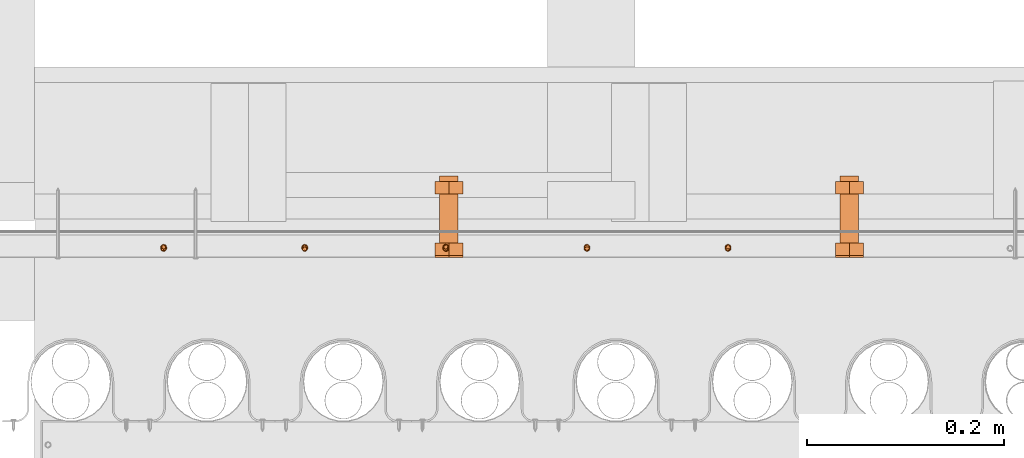
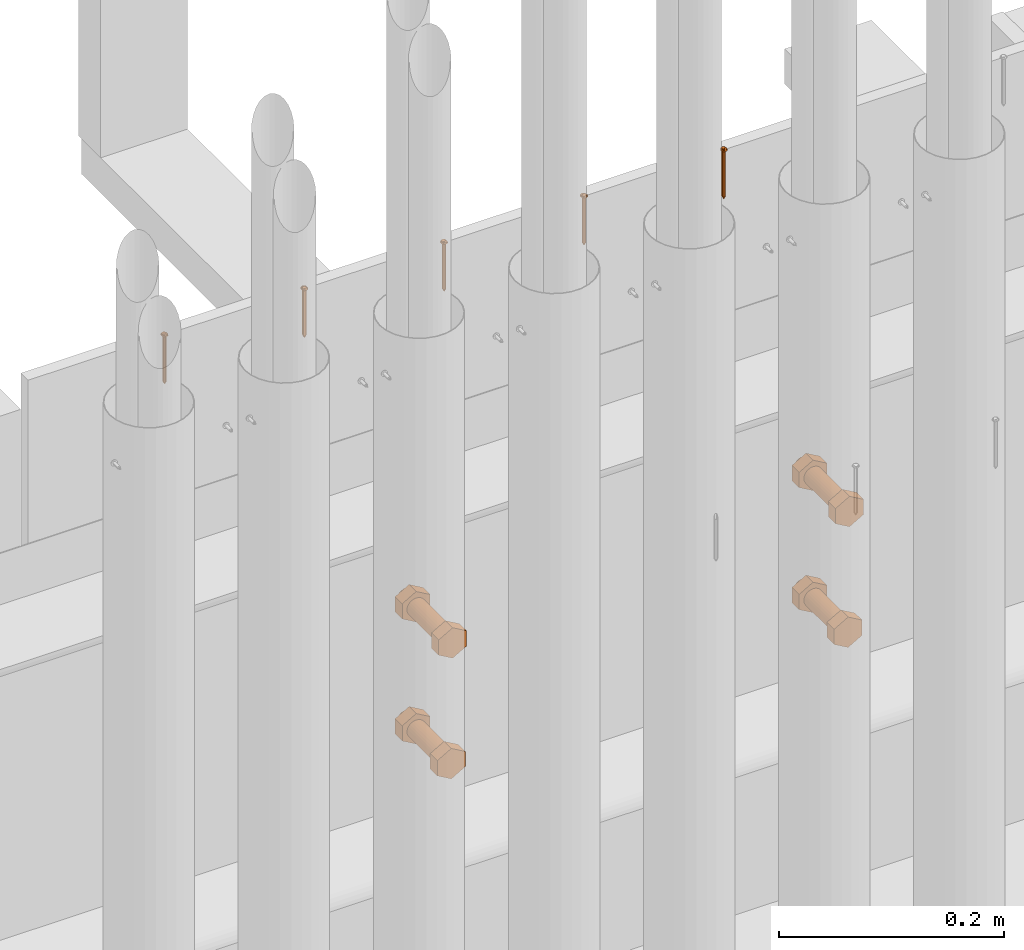
# One storey, part 30 of 44: 14 proxies.
"""IFC4 building model written with IfcOpenShell, lengths in feet."""

from ifc_helpers import new_model, entity, si_unit, converted_unit, derived_unit, direction, frame, frame_2d, origin, place, context, subcontext, project, spatial, polyline, circle, outline, extrude, source, transform, mapped, material, type_object, type_shapes, element, save


model = new_model("IFC4")

# Units and contexts
model_context = context("Model", 3, precision=0.0001, world=origin(), true_north=direction((6.12303176911189e-17, 1.0)))
body_context = subcontext(model_context, "Body", "Model", "MODEL_VIEW")
ifc_project = project(units=[converted_unit("LENGTHUNIT", "FOOT", entity("IfcRatioMeasure", 0.3048), si_unit("LENGTHUNIT", "METRE"), dimensions=[1, 0, 0, 0, 0, 0, 0]), converted_unit("AREAUNIT", "SQUARE FOOT", entity("IfcRatioMeasure", 0.09290304), si_unit("AREAUNIT", "SQUARE_METRE"), dimensions=[2, 0, 0, 0, 0, 0, 0]), converted_unit("VOLUMEUNIT", "CUBIC FOOT", entity("IfcRatioMeasure", 0.028316846592), si_unit("VOLUMEUNIT", "CUBIC_METRE"), dimensions=[3, 0, 0, 0, 0, 0, 0]), converted_unit("PLANEANGLEUNIT", "DEGREE", entity("IfcRatioMeasure", 0.0174532925199433), si_unit("PLANEANGLEUNIT", "RADIAN"), dimensions=[0, 0, 0, 0, 0, 0, 0]), si_unit("MASSUNIT", "GRAM", prefix="KILO"), derived_unit("MASSDENSITYUNIT", [(si_unit("MASSUNIT", "GRAM", prefix="KILO"), 1), (si_unit("LENGTHUNIT", "METRE"), -3)]), derived_unit("MOMENTOFINERTIAUNIT", [(si_unit("LENGTHUNIT", "METRE"), 4)]), si_unit("TIMEUNIT", "SECOND"), si_unit("FREQUENCYUNIT", "HERTZ"), si_unit("THERMODYNAMICTEMPERATUREUNIT", "DEGREE_CELSIUS"), derived_unit("THERMALTRANSMITTANCEUNIT", [(si_unit("MASSUNIT", "GRAM", prefix="KILO"), 1), (si_unit("THERMODYNAMICTEMPERATUREUNIT", "KELVIN"), -1), (si_unit("TIMEUNIT", "SECOND"), -3)]), derived_unit("VOLUMETRICFLOWRATEUNIT", [(si_unit("LENGTHUNIT", "METRE"), 3), (si_unit("TIMEUNIT", "SECOND"), -1)]), si_unit("ELECTRICCURRENTUNIT", "AMPERE"), si_unit("ELECTRICVOLTAGEUNIT", "VOLT"), si_unit("POWERUNIT", "WATT"), si_unit("FORCEUNIT", "NEWTON"), si_unit("ILLUMINANCEUNIT", "LUX"), si_unit("LUMINOUSFLUXUNIT", "LUMEN"), si_unit("LUMINOUSINTENSITYUNIT", "CANDELA"), derived_unit("USERDEFINED", [(si_unit("MASSUNIT", "GRAM", prefix="KILO"), -1), (si_unit("LENGTHUNIT", "METRE"), -2), (si_unit("TIMEUNIT", "SECOND"), 3), (si_unit("LUMINOUSFLUXUNIT", "LUMEN"), 1)]), derived_unit("LINEARVELOCITYUNIT", [(si_unit("LENGTHUNIT", "METRE"), 1), (si_unit("TIMEUNIT", "SECOND"), -1)]), si_unit("PRESSUREUNIT", "PASCAL"), derived_unit("USERDEFINED", [(si_unit("LENGTHUNIT", "METRE"), -2), (si_unit("MASSUNIT", "GRAM", prefix="KILO"), 1), (si_unit("TIMEUNIT", "SECOND"), -2)]), derived_unit("LINEARFORCEUNIT", [(si_unit("MASSUNIT", "GRAM", prefix="KILO"), 1), (si_unit("LENGTHUNIT", "METRE"), 1), (si_unit("TIMEUNIT", "SECOND"), -2), (si_unit("LENGTHUNIT", "METRE"), -1)]), derived_unit("PLANARFORCEUNIT", [(si_unit("MASSUNIT", "GRAM", prefix="KILO"), 1), (si_unit("LENGTHUNIT", "METRE"), 1), (si_unit("TIMEUNIT", "SECOND"), -2), (si_unit("LENGTHUNIT", "METRE"), -2)])], contexts=[model_context])

# Site, building, storey
site_placement = place(None, origin())
site = spatial("IfcSite", under=ifc_project, at=site_placement, CompositionType="ELEMENT")
building_placement = place(site_placement, origin())
building = spatial("IfcBuilding", under=site, at=building_placement, CompositionType="ELEMENT")
storey_placement = place(building_placement, origin())
storey = spatial("IfcBuildingStorey", under=building, at=storey_placement, CompositionType="ELEMENT", Elevation=0.0)

# Proxies
ifc_material_1 = material(Category="Materials")
building_element_proxy_type_1 = type_object("IfcBuildingElementProxyType", PredefinedType="NOTDEFINED", material=ifc_material_1)
cartesian_point_1 = entity("IfcCartesianPoint", [0.0, -0.00520833333344464, -0.164340723974429])
vertex_point_1 = entity("IfcVertexPoint", cartesian_point_1)
cartesian_point_2 = entity("IfcCartesianPoint", [0.0, 0.00520833333334609, -0.164340723974429])
vertex_point_2 = entity("IfcVertexPoint", cartesian_point_2)
cartesian_point_3 = entity("IfcCartesianPoint", [0.0, 0.0, -0.164340723974429])
ifc_direction_1 = entity("IfcDirection", [0.0, 0.0, 1.0])
ifc_direction_2 = entity("IfcDirection", [0.0, 1.0, 0.0])
edge_curve_1 = entity("IfcEdgeCurve", vertex_point_1, vertex_point_2, entity("IfcTrimmedCurve", entity("IfcCircle", entity("IfcAxis2Placement3D", cartesian_point_3, ifc_direction_1, ifc_direction_2), 0.00520833333339537), [cartesian_point_1], [cartesian_point_2], True, "CARTESIAN"), True)
vertex_point_3 = entity("IfcVertexPoint", cartesian_point_3)
ifc_direction_3 = entity("IfcDirection", [0.0, -1.0, 0.0])
edge_curve_2 = entity("IfcEdgeCurve", vertex_point_2, vertex_point_3, entity("IfcTrimmedCurve", entity("IfcLine", cartesian_point_2, entity("IfcVector", ifc_direction_3, 1.0)), [cartesian_point_2], [cartesian_point_3], True, "CARTESIAN"), True)
edge_curve_3 = entity("IfcEdgeCurve", vertex_point_3, vertex_point_1, entity("IfcTrimmedCurve", entity("IfcLine", cartesian_point_3, entity("IfcVector", ifc_direction_3, 1.0)), [cartesian_point_3], [cartesian_point_1], True, "CARTESIAN"), True)
edge_curve_4 = entity("IfcEdgeCurve", vertex_point_2, vertex_point_1, entity("IfcTrimmedCurve", entity("IfcCircle", entity("IfcAxis2Placement3D", cartesian_point_3, ifc_direction_1, ifc_direction_2), 0.00520833333339537), [cartesian_point_2], [cartesian_point_1], True, "CARTESIAN"), True)
cartesian_point_4 = entity("IfcCartesianPoint", [0.0, 0.0, -0.174757390640864])
vertex_point_4 = entity("IfcVertexPoint", cartesian_point_4)
edge_curve_5 = entity("IfcEdgeCurve", vertex_point_4, vertex_point_2, entity("IfcTrimmedCurve", entity("IfcLine", cartesian_point_4, entity("IfcVector", entity("IfcDirection", [0.0, 0.447213595512766, 0.894427190993512]), 1.0)), [cartesian_point_4], [cartesian_point_2], True, "CARTESIAN"), True)
edge_curve_6 = entity("IfcEdgeCurve", vertex_point_1, vertex_point_4, entity("IfcTrimmedCurve", entity("IfcLine", cartesian_point_1, entity("IfcVector", entity("IfcDirection", [0.0, 0.447213595512751, -0.894427190993519]), 1.0)), [cartesian_point_1], [cartesian_point_4], True, "CARTESIAN"), True)
cartesian_point_5 = entity("IfcCartesianPoint", [-0.0052083333333639, 0.0, -0.164340723974429])
cartesian_point_6 = entity("IfcCartesianPoint", [0.0, 0.0, -0.169209575232054])
ifc_direction_4 = entity("IfcDirection", [0.0, 0.0, -1.0])
cartesian_point_7 = entity("IfcCartesianPoint", [0.0, 0.0104166666665518, 0.0])
vertex_point_5 = entity("IfcVertexPoint", cartesian_point_7)
cartesian_point_8 = entity("IfcCartesianPoint", [0.0, -0.0104166666669052, 0.0])
vertex_point_6 = entity("IfcVertexPoint", cartesian_point_8)
cartesian_point_9 = entity("IfcCartesianPoint", [0.0, 0.0, 0.0])
ifc_direction_5 = entity("IfcDirection", [0.0, 0.0, -1.0])
ifc_direction_6 = entity("IfcDirection", [0.0, -1.0, 0.0])
edge_curve_7 = entity("IfcEdgeCurve", vertex_point_5, vertex_point_6, entity("IfcTrimmedCurve", entity("IfcCircle", entity("IfcAxis2Placement3D", cartesian_point_9, ifc_direction_5, ifc_direction_6), 0.0104166666667285), [cartesian_point_7], [cartesian_point_8], True, "CARTESIAN"), True)
vertex_point_7 = entity("IfcVertexPoint", cartesian_point_9)
ifc_direction_7 = entity("IfcDirection", [0.0, 1.0, 0.0])
edge_curve_8 = entity("IfcEdgeCurve", vertex_point_6, vertex_point_7, entity("IfcTrimmedCurve", entity("IfcLine", cartesian_point_8, entity("IfcVector", ifc_direction_7, 1.0)), [cartesian_point_8], [cartesian_point_9], True, "CARTESIAN"), True)
edge_curve_9 = entity("IfcEdgeCurve", vertex_point_7, vertex_point_5, entity("IfcTrimmedCurve", entity("IfcLine", cartesian_point_9, entity("IfcVector", ifc_direction_7, 1.0)), [cartesian_point_9], [cartesian_point_7], True, "CARTESIAN"), True)
edge_curve_10 = entity("IfcEdgeCurve", vertex_point_6, vertex_point_5, entity("IfcTrimmedCurve", entity("IfcCircle", entity("IfcAxis2Placement3D", cartesian_point_9, ifc_direction_5, ifc_direction_6), 0.0104166666667285), [cartesian_point_8], [cartesian_point_7], True, "CARTESIAN"), True)
cartesian_point_10 = entity("IfcCartesianPoint", [0.0, 0.0, 0.00520833333310164])
vertex_point_8 = entity("IfcVertexPoint", cartesian_point_10)
cartesian_point_11 = entity("IfcCartesianPoint", [0.0, -0.00520833333357187, 0.00520833333310168])
vertex_point_9 = entity("IfcVertexPoint", cartesian_point_11)
edge_curve_11 = entity("IfcEdgeCurve", vertex_point_8, vertex_point_9, entity("IfcTrimmedCurve", entity("IfcLine", cartesian_point_10, entity("IfcVector", ifc_direction_6, 1.0)), [cartesian_point_10], [cartesian_point_11], True, "CARTESIAN"), True)
cartesian_point_12 = entity("IfcCartesianPoint", [0.0, 0.00520833333321853, 0.00520833333310159])
vertex_point_10 = entity("IfcVertexPoint", cartesian_point_12)
ifc_direction_8 = entity("IfcDirection", [0.0, 0.0, 1.0])
edge_curve_12 = entity("IfcEdgeCurve", vertex_point_9, vertex_point_10, entity("IfcTrimmedCurve", entity("IfcCircle", entity("IfcAxis2Placement3D", cartesian_point_10, ifc_direction_8, ifc_direction_6), 0.00520833333339523), [cartesian_point_11], [cartesian_point_12], True, "CARTESIAN"), True)
edge_curve_13 = entity("IfcEdgeCurve", vertex_point_10, vertex_point_8, entity("IfcTrimmedCurve", entity("IfcLine", cartesian_point_12, entity("IfcVector", ifc_direction_6, 1.0)), [cartesian_point_12], [cartesian_point_10], True, "CARTESIAN"), True)
edge_curve_14 = entity("IfcEdgeCurve", vertex_point_10, vertex_point_9, entity("IfcTrimmedCurve", entity("IfcCircle", entity("IfcAxis2Placement3D", cartesian_point_10, ifc_direction_8, ifc_direction_6), 0.00520833333339523), [cartesian_point_12], [cartesian_point_11], True, "CARTESIAN"), True)
ifc_direction_9 = entity("IfcDirection", [1.0, 0.0, 0.0])
edge_curve_15 = entity("IfcEdgeCurve", vertex_point_9, vertex_point_6, entity("IfcTrimmedCurve", entity("IfcCircle", entity("IfcAxis2Placement3D", entity("IfcCartesianPoint", [0.0, -0.00520833333357193, 0.0]), ifc_direction_9, ifc_direction_6), 0.00520833333333331), [cartesian_point_11], [cartesian_point_8], True, "CARTESIAN"), True)
edge_curve_16 = entity("IfcEdgeCurve", vertex_point_5, vertex_point_10, entity("IfcTrimmedCurve", entity("IfcCircle", entity("IfcAxis2Placement3D", entity("IfcCartesianPoint", [0.0, 0.0052083333332185, 0.0]), ifc_direction_9, ifc_direction_7), 0.00520833333333331), [cartesian_point_7], [cartesian_point_12], True, "CARTESIAN"), True)
cartesian_point_13 = entity("IfcCartesianPoint", [0.00520833333332085, 0.0, 0.0])
cartesian_point_14 = entity("IfcCartesianPoint", [0.0104166666666542, 0.0, 0.0])
cartesian_point_15 = entity("IfcCartesianPoint", [0.0052083333333208, 0.0, 0.00520833333310163])
cartesian_point_16 = entity("IfcCartesianPoint", [0.0, -0.00520833333348769, 0.0])
vertex_point_11 = entity("IfcVertexPoint", cartesian_point_16)
cartesian_point_17 = entity("IfcCartesianPoint", [0.0, 0.00520833333317898, 0.0])
vertex_point_12 = entity("IfcVertexPoint", cartesian_point_17)
cartesian_point_18 = entity("IfcCartesianPoint", [0.0, 0.0, 0.0])
ifc_direction_10 = entity("IfcDirection", [0.0, 0.0, 1.0])
ifc_direction_11 = entity("IfcDirection", [0.0, 1.0, 0.0])
edge_curve_17 = entity("IfcEdgeCurve", vertex_point_11, vertex_point_12, entity("IfcTrimmedCurve", entity("IfcCircle", entity("IfcAxis2Placement3D", cartesian_point_18, ifc_direction_10, ifc_direction_11), 0.00520833333333333), [cartesian_point_16], [cartesian_point_17], True, "CARTESIAN"), True)
edge_curve_18 = entity("IfcEdgeCurve", vertex_point_12, vertex_point_11, entity("IfcTrimmedCurve", entity("IfcCircle", entity("IfcAxis2Placement3D", cartesian_point_18, ifc_direction_10, ifc_direction_11), 0.00520833333333333), [cartesian_point_17], [cartesian_point_16], True, "CARTESIAN"), True)
cartesian_point_19 = entity("IfcCartesianPoint", [0.0, -0.0052083333334891, -0.164340723974537])
vertex_point_13 = entity("IfcVertexPoint", cartesian_point_19)
cartesian_point_20 = entity("IfcCartesianPoint", [0.0, 0.00520833333317756, -0.164340723974537])
vertex_point_14 = entity("IfcVertexPoint", cartesian_point_20)
cartesian_point_21 = entity("IfcCartesianPoint", [0.0, 0.0, -0.164340723974537])
ifc_direction_12 = entity("IfcDirection", [0.0, 0.0, -1.0])
edge_curve_19 = entity("IfcEdgeCurve", vertex_point_13, vertex_point_14, entity("IfcTrimmedCurve", entity("IfcCircle", entity("IfcAxis2Placement3D", cartesian_point_21, ifc_direction_12, ifc_direction_11), 0.00520833333333333), [cartesian_point_19], [cartesian_point_20], True, "CARTESIAN"), True)
edge_curve_20 = entity("IfcEdgeCurve", vertex_point_14, vertex_point_13, entity("IfcTrimmedCurve", entity("IfcCircle", entity("IfcAxis2Placement3D", cartesian_point_21, ifc_direction_12, ifc_direction_11), 0.00520833333333333), [cartesian_point_20], [cartesian_point_19], True, "CARTESIAN"), True)
edge_curve_21 = entity("IfcEdgeCurve", vertex_point_11, vertex_point_13, entity("IfcTrimmedCurve", entity("IfcLine", cartesian_point_16, entity("IfcVector", ifc_direction_12, 1.0)), [cartesian_point_16], [cartesian_point_19], True, "CARTESIAN"), True)
edge_curve_22 = entity("IfcEdgeCurve", vertex_point_14, vertex_point_12, entity("IfcTrimmedCurve", entity("IfcLine", cartesian_point_17, entity("IfcVector", ifc_direction_10, 1.0)), [cartesian_point_20], [cartesian_point_17], True, "CARTESIAN"), True)
shared_shape_1 = source(origin(), body_context, "Body", "AdvancedBrep", [
    entity("IfcAdvancedBrep", entity("IfcClosedShell", [entity("IfcAdvancedFace", [entity("IfcFaceOuterBound", entity("IfcEdgeLoop", [entity("IfcOrientedEdge", None, None, edge_curve_1, True), entity("IfcOrientedEdge", None, None, edge_curve_2, True), entity("IfcOrientedEdge", None, None, edge_curve_3, True)]), True)], entity("IfcPlane", entity("IfcAxis2Placement3D", cartesian_point_3, ifc_direction_1, ifc_direction_2)), True), entity("IfcAdvancedFace", [entity("IfcFaceOuterBound", entity("IfcEdgeLoop", [entity("IfcOrientedEdge", None, None, edge_curve_4, True), entity("IfcOrientedEdge", None, None, edge_curve_3, False), entity("IfcOrientedEdge", None, None, edge_curve_2, False)]), True)], entity("IfcPlane", entity("IfcAxis2Placement3D", cartesian_point_3, ifc_direction_1, ifc_direction_2)), True), entity("IfcAdvancedFace", [entity("IfcFaceOuterBound", entity("IfcEdgeLoop", [entity("IfcOrientedEdge", None, None, edge_curve_5, True), entity("IfcOrientedEdge", None, None, edge_curve_1, False), entity("IfcOrientedEdge", None, None, edge_curve_6, True)]), True)], entity("IfcSurfaceOfRevolution", entity("IfcArbitraryOpenProfileDef", "CURVE", None, entity("IfcTrimmedCurve", entity("IfcLine", cartesian_point_4, entity("IfcVector", entity("IfcDirection", [0.447213595512749, 0.0, -0.894427190993521]), 1.0)), [cartesian_point_5], [cartesian_point_4], True, "CARTESIAN")), None, entity("IfcAxis1Placement", cartesian_point_6, ifc_direction_4)), True), entity("IfcAdvancedFace", [entity("IfcFaceOuterBound", entity("IfcEdgeLoop", [entity("IfcOrientedEdge", None, None, edge_curve_6, False), entity("IfcOrientedEdge", None, None, edge_curve_4, False), entity("IfcOrientedEdge", None, None, edge_curve_5, False)]), True)], entity("IfcSurfaceOfRevolution", entity("IfcArbitraryOpenProfileDef", "CURVE", None, entity("IfcTrimmedCurve", entity("IfcLine", cartesian_point_4, entity("IfcVector", entity("IfcDirection", [0.447213595512749, 0.0, -0.894427190993521]), 1.0)), [cartesian_point_5], [cartesian_point_4], True, "CARTESIAN")), None, entity("IfcAxis1Placement", cartesian_point_6, ifc_direction_4)), True)])),
    entity("IfcAdvancedBrep", entity("IfcClosedShell", [entity("IfcAdvancedFace", [entity("IfcFaceOuterBound", entity("IfcEdgeLoop", [entity("IfcOrientedEdge", None, None, edge_curve_7, True), entity("IfcOrientedEdge", None, None, edge_curve_8, True), entity("IfcOrientedEdge", None, None, edge_curve_9, True)]), True)], entity("IfcPlane", entity("IfcAxis2Placement3D", cartesian_point_9, ifc_direction_5, ifc_direction_6)), True), entity("IfcAdvancedFace", [entity("IfcFaceOuterBound", entity("IfcEdgeLoop", [entity("IfcOrientedEdge", None, None, edge_curve_10, True), entity("IfcOrientedEdge", None, None, edge_curve_9, False), entity("IfcOrientedEdge", None, None, edge_curve_8, False)]), True)], entity("IfcPlane", entity("IfcAxis2Placement3D", cartesian_point_9, ifc_direction_5, ifc_direction_6)), True), entity("IfcAdvancedFace", [entity("IfcFaceOuterBound", entity("IfcEdgeLoop", [entity("IfcOrientedEdge", None, None, edge_curve_11, True), entity("IfcOrientedEdge", None, None, edge_curve_12, True), entity("IfcOrientedEdge", None, None, edge_curve_13, True)]), True)], entity("IfcPlane", entity("IfcAxis2Placement3D", cartesian_point_10, ifc_direction_8, ifc_direction_6)), True), entity("IfcAdvancedFace", [entity("IfcFaceOuterBound", entity("IfcEdgeLoop", [entity("IfcOrientedEdge", None, None, edge_curve_13, False), entity("IfcOrientedEdge", None, None, edge_curve_14, True), entity("IfcOrientedEdge", None, None, edge_curve_11, False)]), True)], entity("IfcPlane", entity("IfcAxis2Placement3D", cartesian_point_10, ifc_direction_8, ifc_direction_6)), True), entity("IfcAdvancedFace", [entity("IfcFaceOuterBound", entity("IfcEdgeLoop", [entity("IfcOrientedEdge", None, None, edge_curve_12, False), entity("IfcOrientedEdge", None, None, edge_curve_15, True), entity("IfcOrientedEdge", None, None, edge_curve_7, False), entity("IfcOrientedEdge", None, None, edge_curve_16, True)]), True)], entity("IfcSurfaceOfRevolution", entity("IfcArbitraryOpenProfileDef", "CURVE", None, entity("IfcTrimmedCurve", entity("IfcCircle", entity("IfcAxis2Placement3D", cartesian_point_13, ifc_direction_6, ifc_direction_9), 0.00520833333333331), [cartesian_point_14], [cartesian_point_15], True, "CARTESIAN")), None, entity("IfcAxis1Placement", cartesian_point_10, ifc_direction_8)), True), entity("IfcAdvancedFace", [entity("IfcFaceOuterBound", entity("IfcEdgeLoop", [entity("IfcOrientedEdge", None, None, edge_curve_14, False), entity("IfcOrientedEdge", None, None, edge_curve_16, False), entity("IfcOrientedEdge", None, None, edge_curve_10, False), entity("IfcOrientedEdge", None, None, edge_curve_15, False)]), True)], entity("IfcSurfaceOfRevolution", entity("IfcArbitraryOpenProfileDef", "CURVE", None, entity("IfcTrimmedCurve", entity("IfcCircle", entity("IfcAxis2Placement3D", cartesian_point_13, ifc_direction_6, ifc_direction_9), 0.00520833333333331), [cartesian_point_14], [cartesian_point_15], True, "CARTESIAN")), None, entity("IfcAxis1Placement", cartesian_point_10, ifc_direction_8)), True)])),
    entity("IfcAdvancedBrep", entity("IfcClosedShell", [entity("IfcAdvancedFace", [entity("IfcFaceOuterBound", entity("IfcEdgeLoop", [entity("IfcOrientedEdge", None, None, edge_curve_17, True), entity("IfcOrientedEdge", None, None, edge_curve_18, True)]), True)], entity("IfcPlane", entity("IfcAxis2Placement3D", cartesian_point_17, ifc_direction_10, entity("IfcDirection", [-1.0, 0.0, 0.0]))), True), entity("IfcAdvancedFace", [entity("IfcFaceOuterBound", entity("IfcEdgeLoop", [entity("IfcOrientedEdge", None, None, edge_curve_19, True), entity("IfcOrientedEdge", None, None, edge_curve_20, True)]), True)], entity("IfcPlane", entity("IfcAxis2Placement3D", cartesian_point_20, ifc_direction_12, entity("IfcDirection", [1.0, 0.0, 0.0]))), True), entity("IfcAdvancedFace", [entity("IfcFaceOuterBound", entity("IfcEdgeLoop", [entity("IfcOrientedEdge", None, None, edge_curve_17, False), entity("IfcOrientedEdge", None, None, edge_curve_21, True), entity("IfcOrientedEdge", None, None, edge_curve_20, False), entity("IfcOrientedEdge", None, None, edge_curve_22, True)]), True)], entity("IfcCylindricalSurface", entity("IfcAxis2Placement3D", cartesian_point_21, ifc_direction_10, ifc_direction_11), 0.00520833333333333), True), entity("IfcAdvancedFace", [entity("IfcFaceOuterBound", entity("IfcEdgeLoop", [entity("IfcOrientedEdge", None, None, edge_curve_18, False), entity("IfcOrientedEdge", None, None, edge_curve_22, False), entity("IfcOrientedEdge", None, None, edge_curve_19, False), entity("IfcOrientedEdge", None, None, edge_curve_21, False)]), True)], entity("IfcCylindricalSurface", entity("IfcAxis2Placement3D", cartesian_point_21, ifc_direction_10, ifc_direction_11), 0.00520833333333333), True)])),
])
type_shapes(building_element_proxy_type_1, [shared_shape_1])
for number, where in (
    (1, (1489.64084494699, 4.69459660830872, 10.7226156988171)),
    (2, (1489.1710786449, 4.69459660830872, 10.7226156988171)),
    (3, (1488.7013123428, 4.69459660830872, 10.7226156988171)),
    (4, (1488.2315460407, 4.69459660830872, 10.7226156988171)),
    (5, (1487.76177973861, 4.69459660830872, 10.7226156988171)),
    (6, (1489.64084494699, 4.69792994164228, 10.7226156988171)),
    (7, (1489.1710786449, 4.69792994164228, 10.7226156988171)),
    (8, (1488.7013123428, 4.69792994164228, 10.7226156988171)),
    (9, (1488.2315460407, 4.69792994164228, 10.7226156988171)),
    (10, (1487.76177973861, 4.69792994164228, 10.7226156988171)),
):
    element("IfcBuildingElementProxy", number, at=place(storey_placement, frame(where)), inside=storey, type_object=building_element_proxy_type_1, material=ifc_material_1, PredefinedType="NOTDEFINED", context=body_context, shape_type="MappedRepresentation", body=[
        mapped(shared_shape_1, transform((0.0, 0.0, 0.0), scale=1.0)),
    ])
ifc_material_2 = material(Name="EXPOSED LAG BOLTS", Category="Materials")
building_element_proxy_type_2 = type_object("IfcBuildingElementProxyType", PredefinedType="NOTDEFINED", material=ifc_material_2)
shared_shape_2 = source(origin(), body_context, "Body", "SweptSolid", [
    extrude(outline(polyline([(-0.0270632938682657, -0.0468750000000126), (0.0270632938682422, -0.0468750000000126), (0.0541265877365393, 0.0), (0.0270632938683089, 0.0468749999999875), (-0.0270632938682854, 0.0468749999999874), (-0.0541265877365392, 0.0), (-0.0270632938682657, -0.0468750000000126)])), frame((0.0, 0.0, -0.211772443958151), z_axis=(0.0, 0.0, 1.0), x_axis=(0.866025403784438, -0.500000000000001, 0.0)), (0.0, 0.0, 1.0), 0.0416666666666658),
    extrude(outline(polyline([(-0.0270632938682735, -0.046875000000008), (0.0270632938682734, -0.046875000000008), (0.0541265877365273, 0.0), (0.0270632938682302, 0.046875000000033), (-0.02706329386823, 0.0468750000000332), (-0.0541265877365275, 0.0), (-0.0270632938682735, -0.046875000000008)])), frame((0.0, 0.0, 0.0), z_axis=(0.0, 0.0, 1.0), x_axis=(0.0, -1.0, 0.0)), (0.0, 0.0, 1.0), 0.0416666666666658),
    extrude(circle(Radius=0.03125, at=frame_2d((1.59347439296311e-18, -5.04857679510219e-17), x_axis=(1.0, 0.0))), frame((0.0, 0.0, -0.230395832861888), z_axis=(0.0, 0.0, 1.0), x_axis=(0.0, 1.0, 0.0)), (0.0, 0.0, 1.0), 0.230395832861882),
])
type_shapes(building_element_proxy_type_2, [shared_shape_2])
proxy_1_placement = place(storey_placement, frame((1490.04482615351, 4.7052400377664, 9.31485268691632), z_axis=(0.0, -1.0, 0.0), x_axis=(1.0, 0.0, 0.0)))
element("IfcBuildingElementProxy", 11, at=proxy_1_placement, inside=storey, type_object=building_element_proxy_type_2, material=ifc_material_2, PredefinedType="NOTDEFINED", context=body_context, shape_type="MappedRepresentation", body=[
    mapped(shared_shape_2, transform((0.0, 0.0, 0.0), scale=1.0)),
])
building_element_proxy_type_3 = type_object("IfcBuildingElementProxyType", PredefinedType="NOTDEFINED", material=ifc_material_2)
shared_shape_3 = source(origin(), body_context, "Body", "SweptSolid", [
    extrude(outline(polyline([(-0.0270632938682657, -0.0468750000000126), (0.0270632938682422, -0.0468750000000126), (0.0541265877365393, 0.0), (0.0270632938683089, 0.0468749999999875), (-0.0270632938682854, 0.0468749999999874), (-0.0541265877365392, 0.0), (-0.0270632938682657, -0.0468750000000126)])), frame((0.0, 0.0, -0.212136263837386), z_axis=(0.0, 0.0, 1.0), x_axis=(0.866025403784438, -0.500000000000001, 0.0)), (0.0, 0.0, 1.0), 0.0416666666666658),
    extrude(outline(polyline([(-0.0270632938682735, -0.046875000000008), (0.0270632938682734, -0.046875000000008), (0.0541265877365273, 0.0), (0.0270632938682302, 0.046875000000033), (-0.02706329386823, 0.0468750000000332), (-0.0541265877365275, 0.0), (-0.0270632938682735, -0.046875000000008)])), frame((0.0, 0.0, 0.0), z_axis=(0.0, 0.0, 1.0), x_axis=(0.0, -1.0, 0.0)), (0.0, 0.0, 1.0), 0.0416666666666658),
    extrude(circle(Radius=0.03125, at=frame_2d((1.5934743930386e-18, -5.04857679510219e-17), x_axis=(1.0, 0.0))), frame((0.0, 0.0, -0.230395832861879), z_axis=(0.0, 0.0, 1.0), x_axis=(0.0, 1.0, 0.0)), (0.0, 0.0, 1.0), 0.230395832861873),
])
type_shapes(building_element_proxy_type_3, [shared_shape_3])
proxy_2_placement = place(storey_placement, frame((1488.71149282017, 4.7052400377664, 9.31485268691632), z_axis=(0.0, -1.0, 0.0), x_axis=(1.0, 0.0, 0.0)))
element("IfcBuildingElementProxy", 12, at=proxy_2_placement, inside=storey, type_object=building_element_proxy_type_3, material=ifc_material_2, PredefinedType="NOTDEFINED", context=body_context, shape_type="MappedRepresentation", body=[
    mapped(shared_shape_3, transform((0.0, 0.0, 0.0), scale=1.0)),
])
building_element_proxy_type_4 = type_object("IfcBuildingElementProxyType", PredefinedType="NOTDEFINED", material=ifc_material_2)
shared_shape_4 = source(origin(), body_context, "Body", "SweptSolid", [
    extrude(outline(polyline([(-0.0270632938682657, -0.0468750000000126), (0.0270632938682422, -0.0468750000000126), (0.0541265877365393, 0.0), (0.0270632938683089, 0.0468749999999875), (-0.0270632938682854, 0.0468749999999874), (-0.0541265877365392, 0.0), (-0.0270632938682657, -0.0468750000000126)])), frame((0.0, 0.0, -0.203959943958151), z_axis=(0.0, 0.0, 1.0), x_axis=(0.866025403784438, -0.500000000000001, 0.0)), (0.0, 0.0, 1.0), 0.0416666666666658),
    extrude(outline(polyline([(-0.0270632938682735, -0.046875000000008), (0.0270632938682734, -0.046875000000008), (0.0541265877365273, 0.0), (0.0270632938682302, 0.046875000000033), (-0.02706329386823, 0.0468750000000332), (-0.0541265877365275, 0.0), (-0.0270632938682735, -0.046875000000008)])), frame((0.0, 0.0, 0.0), z_axis=(0.0, 0.0, 1.0), x_axis=(0.0, -1.0, 0.0)), (0.0, 0.0, 1.0), 0.0416666666666658),
    extrude(circle(Radius=0.03125, at=frame_2d((-5.03633338849882e-19, -5.04857679510219e-17), x_axis=(1.0, 0.0))), frame((0.0, 0.0, -0.222583332861891), z_axis=(0.0, 0.0, 1.0), x_axis=(0.0, 1.0, 0.0)), (0.0, 0.0, 1.0), 0.222583332861885),
])
type_shapes(building_element_proxy_type_4, [shared_shape_4])
proxy_3_placement = place(storey_placement, frame((1490.04482615351, 4.7130525377664, 8.88132770689174), z_axis=(0.0, -1.0, 0.0), x_axis=(1.0, 0.0, 0.0)))
element("IfcBuildingElementProxy", 13, at=proxy_3_placement, inside=storey, type_object=building_element_proxy_type_4, material=ifc_material_2, PredefinedType="NOTDEFINED", context=body_context, shape_type="MappedRepresentation", body=[
    mapped(shared_shape_4, transform((0.0, 0.0, 0.0), scale=1.0)),
])
building_element_proxy_type_5 = type_object("IfcBuildingElementProxyType", PredefinedType="NOTDEFINED", material=ifc_material_2)
shared_shape_5 = source(origin(), body_context, "Body", "SweptSolid", [
    extrude(outline(polyline([(-0.0270632938682657, -0.0468750000000126), (0.0270632938682422, -0.0468750000000126), (0.0541265877365393, 0.0), (0.0270632938683089, 0.0468749999999875), (-0.0270632938682854, 0.0468749999999874), (-0.0541265877365392, 0.0), (-0.0270632938682657, -0.0468750000000126)])), frame((0.0, 0.0, -0.20432376383738), z_axis=(0.0, 0.0, 1.0), x_axis=(0.866025403784438, -0.500000000000001, 0.0)), (0.0, 0.0, 1.0), 0.0416666666666658),
    extrude(outline(polyline([(-0.0270632938682735, -0.046875000000008), (0.0270632938682734, -0.046875000000008), (0.0541265877365273, 0.0), (0.0270632938682302, 0.046875000000033), (-0.02706329386823, 0.0468750000000332), (-0.0541265877365275, 0.0), (-0.0270632938682735, -0.046875000000008)])), frame((0.0, 0.0, 0.0), z_axis=(0.0, 0.0, 1.0), x_axis=(0.0, -1.0, 0.0)), (0.0, 0.0, 1.0), 0.0416666666666658),
    extrude(circle(Radius=0.03125, at=frame_2d((-5.03633338774151e-19, -5.04857679510219e-17), x_axis=(1.0, 0.0))), frame((0.0, 0.0, -0.222583332861881), z_axis=(0.0, 0.0, 1.0), x_axis=(0.0, 1.0, 0.0)), (0.0, 0.0, 1.0), 0.222583332861875),
])
type_shapes(building_element_proxy_type_5, [shared_shape_5])
proxy_4_placement = place(storey_placement, frame((1488.71149282017, 4.7130525377664, 8.88132770689174), z_axis=(0.0, -1.0, 0.0), x_axis=(1.0, 0.0, 0.0)))
element("IfcBuildingElementProxy", 14, at=proxy_4_placement, inside=storey, type_object=building_element_proxy_type_5, material=ifc_material_2, PredefinedType="NOTDEFINED", context=body_context, shape_type="MappedRepresentation", body=[
    mapped(shared_shape_5, transform((0.0, 0.0, 0.0), scale=1.0)),
])

save(model, "model.ifc")
